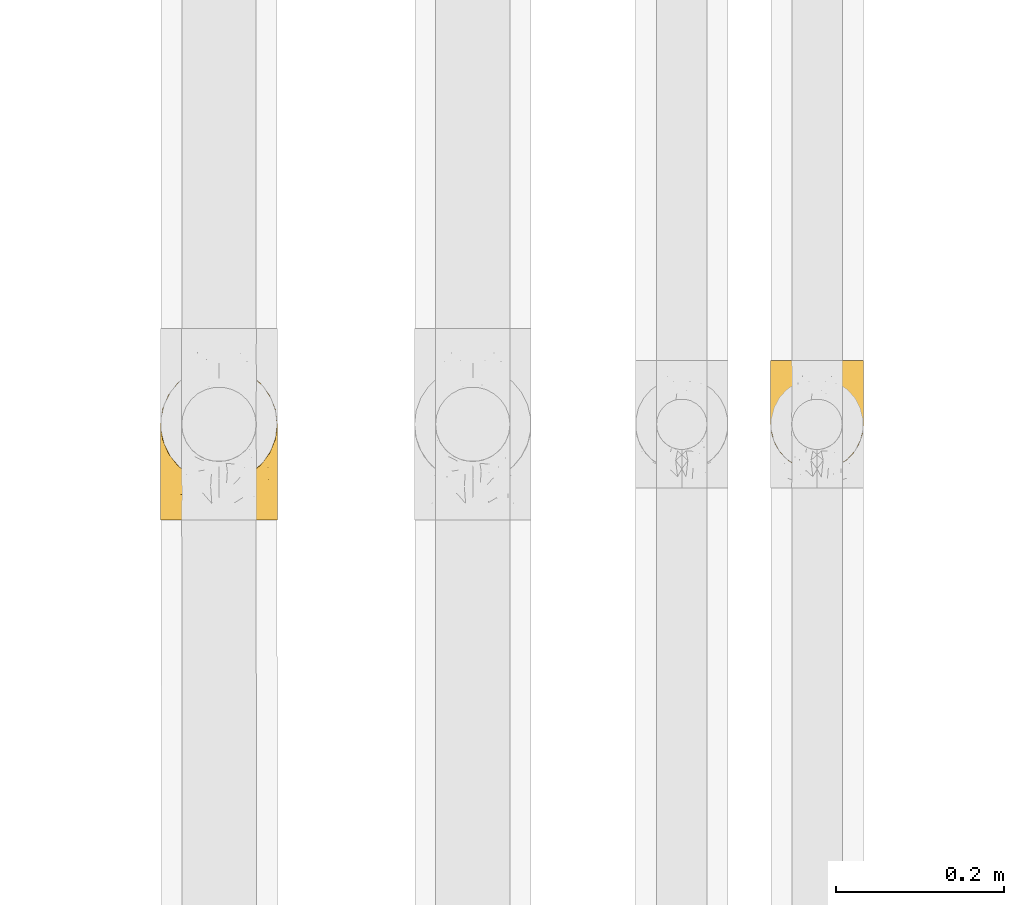
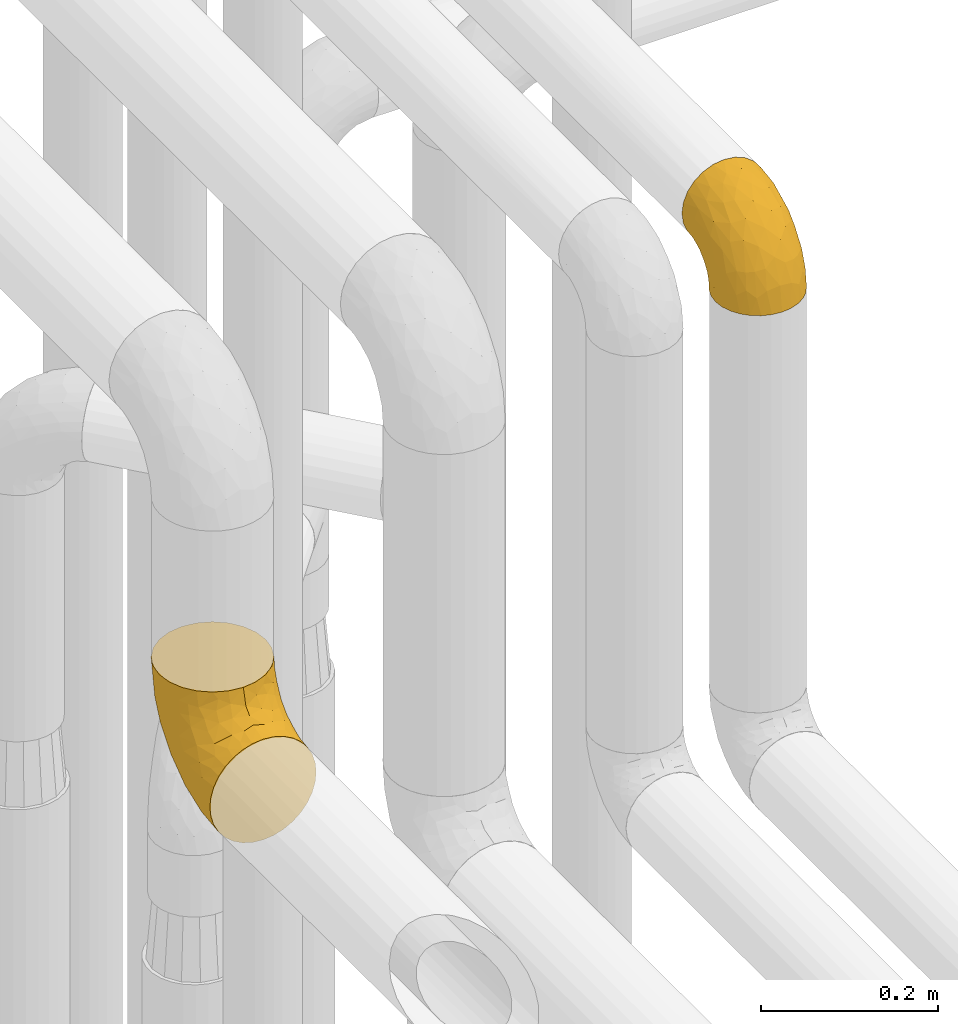
# One storey, part 189 of 827: 2 coverings.
"""IFC2X3 building model written with IfcOpenShell, lengths in millimetres."""

from ifc_helpers import new_model, entity, si_unit, converted_unit, derived_unit, direction, frame, origin, place, context, subcontext, project, spatial, faceted_brep, element, save


model = new_model("IFC2X3")

# Units and contexts
model_context = context("Model", 3, precision=0.01, world=origin(), true_north=direction((6.12303176911189e-17, 1.0)))
body_context = subcontext(model_context, "Body", "Model", "MODEL_VIEW")
ifc_project = project(units=[si_unit("LENGTHUNIT", "METRE", prefix="MILLI"), si_unit("AREAUNIT", "SQUARE_METRE"), si_unit("VOLUMEUNIT", "CUBIC_METRE"), converted_unit("PLANEANGLEUNIT", "DEGREE", entity("IfcRatioMeasure", 0.0174532925199433), si_unit("PLANEANGLEUNIT", "RADIAN"), dimensions=[0, 0, 0, 0, 0, 0, 0]), si_unit("MASSUNIT", "GRAM", prefix="KILO"), derived_unit("MASSDENSITYUNIT", [(si_unit("MASSUNIT", "GRAM", prefix="KILO"), 1), (si_unit("LENGTHUNIT", "METRE"), -3)]), derived_unit("MOMENTOFINERTIAUNIT", [(si_unit("LENGTHUNIT", "METRE"), 4)]), si_unit("TIMEUNIT", "SECOND"), si_unit("FREQUENCYUNIT", "HERTZ"), si_unit("THERMODYNAMICTEMPERATUREUNIT", "DEGREE_CELSIUS"), derived_unit("THERMALTRANSMITTANCEUNIT", [(si_unit("MASSUNIT", "GRAM", prefix="KILO"), 1), (si_unit("THERMODYNAMICTEMPERATUREUNIT", "KELVIN"), -1), (si_unit("TIMEUNIT", "SECOND"), -3)]), derived_unit("VOLUMETRICFLOWRATEUNIT", [(si_unit("LENGTHUNIT", "METRE"), 3), (si_unit("TIMEUNIT", "SECOND"), -1)]), derived_unit("MASSFLOWRATEUNIT", [(si_unit("MASSUNIT", "GRAM", prefix="KILO"), 1), (si_unit("TIMEUNIT", "SECOND"), -1)]), derived_unit("ROTATIONALFREQUENCYUNIT", [(si_unit("TIMEUNIT", "SECOND"), -1)]), si_unit("ELECTRICCURRENTUNIT", "AMPERE"), si_unit("ELECTRICVOLTAGEUNIT", "VOLT"), si_unit("POWERUNIT", "WATT"), si_unit("FORCEUNIT", "NEWTON", prefix="KILO"), si_unit("ILLUMINANCEUNIT", "LUX"), si_unit("LUMINOUSFLUXUNIT", "LUMEN"), si_unit("LUMINOUSINTENSITYUNIT", "CANDELA"), derived_unit("USERDEFINED", [(si_unit("MASSUNIT", "GRAM", prefix="KILO"), -1), (si_unit("LENGTHUNIT", "METRE"), -2), (si_unit("TIMEUNIT", "SECOND"), 3), (si_unit("LUMINOUSFLUXUNIT", "LUMEN"), 1)]), derived_unit("LINEARVELOCITYUNIT", [(si_unit("LENGTHUNIT", "METRE"), 1), (si_unit("TIMEUNIT", "SECOND"), -1)]), si_unit("PRESSUREUNIT", "PASCAL"), derived_unit("USERDEFINED", [(si_unit("LENGTHUNIT", "METRE"), -2), (si_unit("MASSUNIT", "GRAM", prefix="KILO"), 1), (si_unit("TIMEUNIT", "SECOND"), -2)]), derived_unit("LINEARFORCEUNIT", [(si_unit("MASSUNIT", "GRAM", prefix="KILO"), 1), (si_unit("LENGTHUNIT", "METRE"), 1), (si_unit("TIMEUNIT", "SECOND"), -2), (si_unit("LENGTHUNIT", "METRE"), -1)]), derived_unit("PLANARFORCEUNIT", [(si_unit("MASSUNIT", "GRAM", prefix="KILO"), 1), (si_unit("LENGTHUNIT", "METRE"), 1), (si_unit("TIMEUNIT", "SECOND"), -2), (si_unit("LENGTHUNIT", "METRE"), -2)])], contexts=[model_context])

# Site, building, storey
site_placement = place(None, origin())
site = spatial("IfcSite", under=ifc_project, at=site_placement, CompositionType="ELEMENT")
building_placement = place(site_placement, origin())
building = spatial("IfcBuilding", under=site, at=building_placement, CompositionType="ELEMENT")
storey_placement = place(building_placement, frame((0.0, 0.0, 28200.0)))
storey = spatial("IfcBuildingStorey", under=building, at=storey_placement, Name="08", CompositionType="ELEMENT", Elevation=28200.0)

# Coverings
covering_1_placement = place(storey_placement, frame((36572.9, 8750.64, 3472.4)))
element("IfcCovering", 1, at=covering_1_placement, inside=storey, Name=":ADSK_", ObjectType=":ADSK_", PredefinedType="INSULATION", context=body_context, shape_type="Brep", body=[
    faceted_brep([(111.9, 56.75, 1.6), (110.51, 44.47, 1.6), (106.43, 32.81, 1.6), (99.86, 22.35, 1.6), (91.12, 13.62, 1.6), (80.66, 7.05, 1.6), (69.0, 2.97, 1.6), (56.75, 1.6, 1.6), (44.47, 2.98, 1.6), (32.81, 7.06, 1.6), (22.35, 13.63, 1.6), (13.62, 22.37, 1.6), (7.05, 32.83, 1.6), (2.97, 44.49, 1.6), (1.6, 56.75, 1.6), (2.55, 65.19, 1.6), (2.98, 69.02, 1.6), (5.02, 74.85, 1.6), (7.06, 80.68, 1.6), (13.63, 91.14, 1.6), (22.37, 99.87, 1.6), (32.83, 106.44, 1.6), (44.49, 110.52, 1.6), (56.75, 111.9, 1.6), (69.02, 110.51, 1.6), (80.68, 106.43, 1.6), (91.14, 99.86, 1.6), (99.87, 91.12, 1.6), (106.44, 80.66, 1.6), (108.48, 74.83, 1.6), (110.52, 69.0, 1.6), (110.95, 65.19, 1.6), (42.47, 132.75, 24.32), (29.17, 132.75, 29.83), (17.75, 132.75, 38.6), (13.37, 132.75, 44.31), (8.98, 132.75, 50.02), (3.47, 132.75, 63.32), (2.71, 132.75, 69.12), (2.15, 132.75, 73.36), (1.6, 132.75, 77.6), (3.47, 132.75, 91.87), (8.98, 132.75, 105.17), (17.75, 132.75, 116.59), (29.17, 132.75, 125.36), (42.47, 132.75, 130.87), (56.75, 132.75, 132.75), (71.02, 132.75, 130.87), (84.32, 132.75, 125.36), (95.74, 132.75, 116.59), (104.51, 132.75, 105.17), (110.02, 132.75, 91.87), (111.9, 132.75, 77.6), (110.78, 132.75, 69.12), (110.02, 132.75, 63.32), (104.51, 132.75, 50.02), (100.12, 132.75, 44.31), (95.74, 132.75, 38.6), (84.32, 132.75, 29.83), (71.02, 132.75, 24.32), (56.75, 132.75, 22.45), (106.06, 106.09, 98.7), (110.5, 106.29, 85.87), (56.75, 98.8, 128.28), (66.53, 110.62, 129.98), (76.28, 79.56, 117.55), (86.35, 82.88, 113.52), (75.96, 101.82, 125.49), (88.56, 109.51, 120.4), (110.32, 60.24, 53.38), (111.9, 62.53, 30.68), (111.9, 66.65, 36.84), (111.9, 70.77, 43.01), (111.9, 74.89, 49.17), (111.9, 79.01, 55.34), (107.8, 75.42, 79.67), (101.47, 78.6, 95.35), (73.78, 54.94, 103.8), (56.75, 67.17, 115.17), (56.75, 40.01, 94.33), (98.04, 101.35, 109.68), (101.71, 27.42, 25.2), (56.75, 6.06, 35.54), (73.2, 7.89, 32.54), (104.0, 54.81, 71.11), (110.96, 49.8, 24.73), (111.08, 83.59, 71.5), (111.9, 85.17, 59.45), (111.9, 91.33, 63.57), (111.9, 97.5, 67.69), (111.9, 103.66, 71.81), (93.24, 19.66, 32.94), (98.07, 32.92, 53.51), (66.48, 86.86, 123.53), (82.04, 19.74, 55.05), (71.11, 29.98, 79.98), (68.82, 15.6, 57.53), (84.42, 11.19, 24.57), (84.13, 42.02, 85.93), (111.9, 58.54, 10.61), (111.9, 60.33, 19.62), (90.72, 25.28, 53.74), (89.42, 62.01, 99.07), (105.96, 42.85, 47.38), (107.26, 37.14, 23.67), (56.75, 19.17, 67.17), (96.16, 51.44, 82.32), (111.9, 114.72, 74.01), (111.9, 119.22, 74.91), (111.9, 123.73, 75.8), (106.76, 115.76, 51.54), (110.57, 110.4, 61.55), (110.3, 102.67, 56.74), (110.29, 119.74, 63.04), (94.17, 125.52, 36.34), (101.01, 123.09, 43.61), (98.9, 115.24, 38.04), (105.68, 124.18, 51.43), (106.0, 108.76, 46.81), (103.59, 105.53, 39.79), (67.59, 112.2, 9.27), (82.4, 109.92, 16.36), (78.41, 108.4, 8.4), (103.94, 89.3, 20.7), (109.96, 78.37, 30.35), (108.51, 78.09, 17.66), (95.93, 110.58, 31.46), (91.02, 108.54, 23.73), (82.23, 114.9, 21.98), (69.32, 124.4, 22.28), (87.66, 124.83, 30.88), (99.66, 92.2, 9.8), (92.5, 100.98, 13.74), (110.75, 69.61, 16.21), (108.97, 87.39, 38.18), (94.99, 102.3, 21.3), (111.03, 70.27, 23.76), (70.18, 116.83, 17.51), (56.75, 114.69, 12.02), (56.75, 122.32, 19.65), (104.65, 94.21, 31.33), (84.42, 120.17, 26.94), (106.33, 96.46, 38.65), (108.73, 97.77, 47.33), (110.14, 89.34, 46.16), (99.67, 101.91, 29.19), (29.08, 120.17, 26.94), (25.83, 124.84, 30.88), (3.2, 102.67, 56.74), (1.6, 97.5, 67.69), (2.92, 110.4, 61.55), (44.17, 124.4, 22.28), (1.6, 58.54, 10.61), (1.6, 60.33, 19.62), (3.35, 89.33, 46.16), (1.6, 79.01, 55.34), (1.6, 85.17, 59.45), (43.33, 116.83, 17.51), (45.92, 112.21, 9.26), (21.01, 101.0, 13.74), (31.11, 109.94, 16.36), (35.1, 108.4, 8.4), (1.6, 114.72, 74.01), (1.6, 123.73, 75.8), (1.6, 128.24, 76.7), (17.57, 110.6, 31.46), (22.49, 108.57, 23.73), (13.83, 101.94, 29.19), (19.33, 125.53, 36.34), (11.9, 119.28, 43.38), (4.99, 78.12, 17.66), (1.6, 103.66, 71.81), (3.2, 119.74, 63.04), (6.74, 115.76, 51.54), (7.5, 108.77, 46.81), (7.81, 124.18, 51.43), (4.53, 87.39, 38.15), (1.6, 74.89, 49.17), (1.6, 62.53, 30.68), (2.75, 69.63, 16.19), (13.84, 92.22, 9.8), (18.52, 102.32, 21.3), (9.57, 89.33, 20.71), (3.54, 78.39, 30.35), (9.91, 105.54, 39.78), (2.46, 70.28, 23.75), (1.6, 66.65, 36.84), (14.6, 115.25, 38.04), (8.86, 94.22, 31.3), (7.16, 96.46, 38.64), (4.77, 97.78, 47.32), (31.28, 114.91, 21.97), (1.6, 70.77, 43.01), (1.6, 91.33, 63.57), (2.41, 83.59, 71.49), (7.44, 106.09, 98.7), (7.52, 42.86, 47.37), (3.17, 60.25, 53.37), (2.53, 49.81, 24.72), (47.01, 88.41, 124.11), (2.99, 106.29, 85.87), (37.53, 101.81, 125.49), (47.09, 110.86, 130.04), (24.94, 109.5, 120.4), (15.45, 101.34, 109.68), (27.14, 82.87, 113.51), (29.35, 42.02, 85.93), (42.38, 29.98, 79.98), (39.72, 54.94, 103.8), (5.69, 75.43, 79.67), (17.32, 51.45, 82.31), (12.02, 78.59, 95.34), (9.48, 54.82, 71.09), (11.77, 27.44, 25.2), (15.41, 32.93, 53.51), (31.43, 19.76, 55.07), (20.24, 19.67, 32.95), (22.76, 25.31, 53.76), (24.06, 62.02, 99.06), (40.27, 7.9, 32.56), (29.05, 11.2, 24.57), (43.27, 15.96, 57.51), (38.2, 77.26, 116.87), (6.22, 37.15, 23.67)], [[[0, 1, 2, 3, 4, 5, 6, 7, 8, 9, 10, 11, 12, 13, 14, 15, 16, 17, 18, 19, 20, 21, 22, 23, 24, 25, 26, 27, 28, 29, 30, 31]], [[32, 33, 34, 35, 36, 37, 38, 39, 40, 41, 42, 43, 44, 45, 46, 47, 48, 49, 50, 51, 52, 53, 54, 55, 56, 57, 58, 59, 60]], [[51, 61, 62]], [[46, 63, 64]], [[65, 66, 67]], [[67, 66, 68]], [[69, 70, 71, 72, 73, 74]], [[75, 61, 76]], [[77, 78, 79]], [[61, 50, 80]], [[49, 80, 50]], [[68, 49, 48]], [[81, 3, 2]], [[82, 6, 83]], [[48, 47, 67]], [[52, 51, 62]], [[84, 75, 76]], [[85, 1, 0]], [[86, 74, 87, 88, 89, 90]], [[91, 81, 92]], [[93, 65, 67]], [[94, 95, 96]], [[49, 68, 80]], [[79, 95, 77]], [[5, 83, 6]], [[82, 83, 96]], [[97, 5, 4]], [[6, 82, 7]], [[84, 69, 75]], [[86, 69, 74]], [[98, 77, 95]], [[97, 83, 5]], [[85, 0, 99, 100, 70]], [[101, 91, 92]], [[77, 98, 102]], [[91, 4, 3]], [[103, 104, 85]], [[103, 81, 104]], [[102, 76, 80]], [[64, 93, 67]], [[97, 94, 83]], [[47, 64, 67]], [[50, 61, 51]], [[81, 91, 3]], [[96, 95, 105]], [[79, 105, 95]], [[101, 98, 94]], [[4, 91, 97]], [[94, 97, 91]], [[104, 81, 2]], [[92, 81, 103]], [[84, 92, 103]], [[106, 98, 101]], [[76, 61, 80]], [[75, 86, 62]], [[102, 80, 66]], [[84, 76, 106]], [[75, 62, 61]], [[62, 90, 107, 108, 109, 52]], [[70, 69, 85]], [[103, 85, 69]], [[94, 98, 95]], [[102, 98, 106]], [[2, 1, 104]], [[85, 104, 1]], [[67, 68, 48]], [[80, 68, 66]], [[62, 86, 90]], [[69, 86, 75]], [[76, 102, 106]], [[77, 102, 66]], [[92, 84, 106]], [[69, 84, 103]], [[46, 64, 47]], [[93, 64, 63]], [[63, 78, 93]], [[77, 93, 78]], [[93, 77, 65]], [[77, 66, 65]], [[82, 96, 105]], [[94, 96, 83]], [[101, 92, 106]], [[94, 91, 101]], [[110, 111, 112]], [[107, 90, 113]], [[114, 115, 116]], [[54, 107, 113]], [[115, 56, 117]], [[118, 119, 116]], [[120, 121, 122]], [[123, 124, 125]], [[99, 0, 31, 30, 100]], [[126, 127, 128]], [[129, 60, 59]], [[58, 114, 130]], [[131, 132, 123]], [[29, 28, 133]], [[130, 59, 58]], [[114, 58, 57]], [[134, 72, 124]], [[121, 127, 135]], [[26, 25, 132]], [[27, 131, 125]], [[27, 125, 28]], [[136, 133, 125]], [[120, 137, 121]], [[137, 138, 139]], [[126, 116, 119]], [[133, 70, 100]], [[138, 120, 23]], [[100, 29, 133]], [[123, 135, 140]], [[129, 141, 128]], [[53, 52, 109, 108, 107, 54]], [[25, 122, 132]], [[24, 122, 25]], [[55, 113, 117]], [[26, 131, 27]], [[142, 119, 143]], [[111, 89, 112]], [[112, 87, 143]], [[144, 134, 142]], [[118, 110, 112]], [[129, 137, 139]], [[128, 141, 126]], [[111, 113, 90]], [[54, 113, 55]], [[74, 73, 144]], [[145, 142, 140]], [[122, 24, 120]], [[132, 122, 121]], [[23, 120, 24]], [[137, 120, 138]], [[60, 129, 139]], [[141, 129, 59]], [[100, 30, 29]], [[28, 125, 133]], [[134, 124, 123]], [[124, 71, 136]], [[89, 88, 87, 112]], [[111, 110, 117]], [[143, 87, 144]], [[118, 116, 115]], [[112, 143, 118]], [[119, 118, 143]], [[143, 144, 142]], [[126, 119, 145]], [[127, 126, 145]], [[130, 126, 141]], [[140, 142, 134]], [[145, 119, 142]], [[135, 127, 145]], [[127, 121, 128]], [[121, 137, 128]], [[129, 128, 137]], [[73, 72, 134]], [[111, 90, 89]], [[74, 144, 87]], [[134, 123, 140]], [[135, 123, 132]], [[140, 135, 145]], [[121, 135, 132]], [[132, 131, 26]], [[125, 131, 123]], [[115, 114, 57]], [[116, 126, 130]], [[111, 117, 113]], [[115, 110, 118]], [[115, 117, 110]], [[115, 57, 56]], [[56, 55, 117]], [[116, 130, 114]], [[59, 130, 141]], [[144, 73, 134]], [[124, 136, 125]], [[70, 133, 136]], [[71, 124, 72]], [[71, 70, 136]], [[32, 146, 147]], [[148, 149, 150]], [[60, 139, 151]], [[15, 14, 152, 153, 16]], [[154, 155, 156]], [[138, 157, 139]], [[138, 158, 157]], [[159, 160, 161]], [[39, 38, 37, 162, 163, 164, 40]], [[165, 166, 167]], [[168, 169, 34]], [[33, 168, 34]], [[170, 19, 18]], [[171, 162, 172]], [[173, 174, 148]], [[169, 173, 175]], [[161, 158, 22]], [[154, 176, 177]], [[23, 22, 158]], [[178, 179, 153]], [[172, 37, 36]], [[20, 19, 180]], [[21, 20, 159]], [[167, 166, 181]], [[170, 182, 180]], [[182, 170, 183]], [[167, 184, 165]], [[185, 186, 183]], [[170, 179, 185]], [[17, 153, 179]], [[157, 151, 139]], [[187, 168, 147]], [[182, 188, 181]], [[22, 21, 161]], [[189, 154, 190]], [[180, 159, 20]], [[172, 150, 171]], [[190, 184, 189]], [[188, 167, 181]], [[190, 174, 184]], [[166, 191, 160]], [[151, 146, 32]], [[37, 172, 162]], [[175, 36, 35]], [[188, 176, 189]], [[176, 182, 183]], [[159, 161, 21]], [[158, 160, 157]], [[158, 161, 160]], [[23, 158, 138]], [[151, 157, 191]], [[60, 151, 32]], [[170, 18, 179]], [[17, 16, 153]], [[183, 170, 185]], [[179, 178, 185]], [[175, 150, 172]], [[150, 173, 148]], [[173, 169, 174]], [[154, 156, 190]], [[184, 174, 187]], [[190, 148, 174]], [[165, 184, 187]], [[189, 176, 154]], [[147, 165, 187]], [[191, 166, 165]], [[184, 167, 189]], [[188, 189, 167]], [[191, 165, 146]], [[181, 160, 159]], [[151, 191, 146]], [[157, 160, 191]], [[176, 192, 177]], [[148, 190, 156]], [[149, 148, 156, 193]], [[149, 171, 150]], [[182, 176, 188]], [[160, 181, 166]], [[181, 159, 182]], [[170, 180, 19]], [[159, 180, 182]], [[147, 168, 33]], [[169, 168, 187]], [[174, 169, 187]], [[35, 169, 175]], [[150, 175, 173]], [[34, 169, 35]], [[172, 36, 175]], [[32, 147, 33]], [[147, 146, 165]], [[192, 176, 183]], [[155, 154, 177]], [[192, 183, 186]], [[185, 178, 186]], [[179, 18, 17]], [[194, 171, 149, 193, 156, 155]], [[195, 42, 41]], [[196, 197, 198]], [[78, 63, 199]], [[197, 155, 177, 192, 186, 178]], [[200, 40, 164, 163, 162, 171]], [[201, 199, 202]], [[203, 204, 205]], [[46, 45, 202]], [[206, 207, 208]], [[194, 197, 209]], [[203, 201, 44]], [[44, 201, 45]], [[43, 203, 44]], [[210, 211, 212]], [[204, 43, 42]], [[212, 197, 196]], [[78, 208, 79]], [[198, 178, 153, 152, 14]], [[204, 195, 211]], [[14, 13, 198]], [[196, 213, 214]], [[206, 215, 207]], [[213, 11, 216]], [[204, 42, 195]], [[11, 213, 12]], [[210, 217, 206]], [[216, 11, 10]], [[210, 206, 218]], [[219, 220, 9]], [[220, 10, 9]], [[207, 105, 79]], [[221, 207, 215]], [[222, 199, 201]], [[8, 7, 82]], [[8, 82, 219]], [[209, 195, 200]], [[215, 216, 220]], [[9, 8, 219]], [[207, 79, 208]], [[221, 82, 105]], [[12, 213, 223]], [[222, 201, 205]], [[204, 211, 218]], [[221, 215, 219]], [[215, 220, 219]], [[216, 10, 220]], [[214, 213, 216]], [[223, 213, 196]], [[217, 214, 216]], [[212, 214, 210]], [[200, 195, 41]], [[211, 195, 209]], [[212, 211, 209]], [[211, 210, 218]], [[40, 200, 41]], [[200, 171, 194]], [[198, 13, 223]], [[197, 178, 198]], [[218, 208, 205]], [[210, 214, 217]], [[198, 223, 196]], [[13, 12, 223]], [[204, 203, 43]], [[201, 203, 205]], [[197, 194, 155]], [[200, 194, 209]], [[208, 218, 206]], [[218, 205, 204]], [[197, 212, 209]], [[214, 212, 196]], [[205, 208, 222]], [[78, 222, 208]], [[78, 199, 222]], [[202, 199, 63]], [[46, 202, 63]], [[201, 202, 45]], [[82, 221, 219]], [[105, 207, 221]], [[216, 215, 217]], [[206, 217, 215]]]),
])
covering_2_placement = place(storey_placement, frame((35847.02, 8691.74, 3028.95)))
element("IfcCovering", 2, at=covering_2_placement, inside=storey, Name=":ADSK_", ObjectType=":ADSK_", PredefinedType="INSULATION", context=body_context, shape_type="Brep", body=[
    faceted_brep([(3.02, 1.6, 84.59), (1.69, 1.6, 71.05), (3.02, 1.6, 57.49), (6.98, 1.6, 44.46), (13.4, 1.6, 32.45), (22.04, 1.61, 21.93), (32.56, 1.62, 13.29), (44.57, 1.63, 6.88), (57.6, 1.64, 2.93), (71.14, 1.65, 1.6), (84.69, 1.66, 2.93), (97.72, 1.67, 6.88), (109.73, 1.68, 13.3), (120.25, 1.69, 21.94), (128.89, 1.7, 32.47), (135.3, 1.7, 44.48), (139.25, 1.71, 57.5), (140.59, 1.71, 71.05), (139.25, 1.71, 84.6), (135.3, 1.7, 97.63), (128.88, 1.7, 109.64), (120.24, 1.69, 120.16), (109.71, 1.68, 128.8), (97.71, 1.67, 135.21), (84.68, 1.66, 139.16), (71.14, 1.65, 140.5), (57.58, 1.64, 139.16), (44.55, 1.63, 135.21), (32.55, 1.62, 128.79), (22.02, 1.61, 120.15), (13.39, 1.6, 109.62), (6.97, 1.6, 97.62), (71.1, 46.2, 185.05), (89.07, 48.58, 185.05), (105.82, 55.53, 185.05), (120.19, 66.58, 185.05), (131.22, 80.98, 185.05), (138.14, 97.73, 185.05), (140.5, 115.71, 185.05), (138.11, 133.68, 185.05), (131.16, 150.43, 185.05), (120.11, 164.8, 185.05), (105.72, 175.83, 185.05), (88.97, 182.75, 185.05), (70.99, 185.1, 185.05), (53.02, 182.72, 185.05), (36.27, 175.77, 185.05), (21.9, 164.72, 185.05), (10.87, 150.33, 185.05), (3.95, 133.57, 185.05), (1.6, 115.6, 185.05), (3.98, 97.62, 185.05), (10.93, 80.88, 185.05), (21.98, 66.5, 185.05), (36.37, 55.48, 185.05), (53.12, 48.55, 185.05), (30.71, 168.98, 152.15), (46.55, 175.16, 141.12), (33.18, 158.76, 114.51), (58.51, 181.23, 153.61), (70.99, 178.85, 137.56), (21.21, 60.47, 33.77), (11.86, 37.65, 39.19), (13.85, 67.77, 46.71), (7.02, 122.9, 113.31), (10.5, 141.28, 135.94), (17.92, 138.24, 104.19), (4.5, 130.26, 147.85), (2.77, 112.44, 123.66), (3.23, 49.74, 65.65), (7.67, 68.05, 59.18), (5.82, 30.87, 50.51), (45.96, 163.58, 109.33), (58.66, 171.55, 118.86), (18.68, 154.97, 140.66), (71.1, 49.13, 7.85), (52.61, 41.68, 8.59), (57.25, 76.32, 19.01), (42.25, 71.52, 22.23), (3.68, 94.09, 92.55), (9.98, 104.14, 79.62), (1.63, 68.6, 92.82), (1.61, 93.82, 118.04), (1.61, 101.92, 133.93), (1.6, 110.02, 149.82), (19.14, 29.3, 27.39), (49.37, 144.81, 75.97), (71.01, 160.52, 93.32), (71.03, 131.37, 55.33), (40.43, 41.73, 13.36), (29.26, 37.38, 19.44), (53.12, 111.51, 41.09), (1.67, 17.55, 73.57), (1.66, 36.82, 76.62), (35.64, 118.95, 56.89), (28.88, 138.31, 85.33), (21.42, 90.61, 49.01), (71.06, 93.38, 26.17), (1.62, 81.21, 105.43), (30.98, 81.17, 34.01), (1.6, 113.07, 169.09), (20.14, 115.62, 71.03), (40.98, 98.75, 37.55), (1.65, 52.71, 84.72), (44.76, 25.35, 141.32), (51.99, 37.49, 154.3), (37.24, 41.94, 150.07), (4.03, 95.84, 167.57), (3.3, 94.09, 150.42), (22.37, 62.75, 164.49), (2.6, 17.88, 83.63), (5.26, 25.24, 96.18), (33.75, 16.56, 131.63), (20.68, 22.29, 122.1), (8.4, 83.67, 166.75), (41.7, 51.81, 175.54), (37.96, 49.59, 162.59), (54.01, 45.41, 168.81), (57.95, 22.0, 144.01), (14.39, 72.89, 165.65), (25.45, 32.44, 131.63), (3.1, 50.57, 98.0), (3.64, 63.77, 110.02), (48.06, 12.87, 137.87), (25.07, 54.59, 152.86), (12.08, 49.26, 124.07), (12.87, 18.25, 110.7), (71.13, 17.14, 144.65), (71.12, 23.93, 146.46), (8.58, 37.06, 109.13), (2.78, 89.71, 134.98), (4.15, 75.21, 124.3), (7.74, 79.99, 150.87), (71.11, 32.08, 154.62), (13.64, 69.2, 152.63), (24.74, 45.44, 140.78), (12.62, 63.69, 140.33), (71.11, 40.23, 162.77), (71.1, 42.05, 169.55), (84.29, 22.02, 144.01), (138.1, 95.95, 167.57), (133.75, 83.77, 166.75), (138.72, 93.43, 149.67), (90.23, 37.52, 154.3), (127.77, 72.98, 165.65), (134.41, 80.09, 150.87), (88.19, 45.44, 168.82), (104.23, 49.65, 162.6), (108.49, 16.61, 131.64), (121.54, 22.37, 122.11), (100.49, 51.86, 175.55), (136.97, 25.35, 96.2), (140.56, 36.94, 76.62), (140.55, 52.83, 84.72), (140.5, 113.18, 169.09), (140.5, 110.13, 149.82), (119.8, 62.83, 164.49), (130.1, 49.34, 124.09), (116.76, 32.51, 131.64), (129.54, 63.78, 140.35), (117.44, 45.5, 140.79), (128.13, 68.82, 152.98), (117.11, 54.66, 152.86), (94.18, 12.89, 137.88), (140.57, 17.67, 73.57), (129.37, 18.35, 110.71), (139.1, 50.68, 98.01), (133.64, 37.16, 109.15), (138.0, 75.31, 124.3), (97.46, 25.38, 141.32), (139.65, 18.0, 83.62), (104.29, 38.18, 146.63), (140.51, 93.94, 118.04), (139.02, 87.74, 134.71), (138.53, 63.88, 110.02), (140.53, 68.72, 92.82), (140.52, 81.33, 105.43), (140.51, 102.03, 133.93), (108.84, 158.82, 114.51), (111.3, 169.05, 152.15), (123.34, 155.06, 140.66), (136.41, 30.97, 50.53), (128.32, 67.85, 46.72), (130.36, 37.75, 39.21), (120.98, 60.56, 33.78), (139.33, 112.55, 123.66), (124.13, 138.32, 104.19), (106.44, 119.01, 56.89), (120.73, 90.68, 49.02), (111.18, 81.25, 34.02), (138.45, 94.2, 92.55), (137.56, 130.37, 147.85), (101.16, 98.79, 37.56), (131.55, 141.38, 135.94), (83.45, 181.26, 153.66), (95.45, 175.2, 141.12), (83.36, 172.62, 121.64), (134.5, 68.16, 59.2), (138.97, 49.85, 65.65), (135.06, 123.01, 113.31), (95.2, 162.88, 107.01), (88.97, 111.54, 41.09), (92.67, 144.84, 75.97), (132.13, 104.24, 79.62), (123.1, 29.39, 27.41), (102.11, 30.53, 11.27), (121.95, 115.71, 71.03), (112.97, 37.45, 19.45), (99.92, 71.58, 22.24), (89.61, 41.72, 8.6), (84.91, 76.36, 19.02), (83.79, 159.71, 94.27), (113.17, 138.38, 85.33)], [[[0, 1, 2, 3, 4, 5, 6, 7, 8, 9, 10, 11, 12, 13, 14, 15, 16, 17, 18, 19, 20, 21, 22, 23, 24, 25, 26, 27, 28, 29, 30, 31]], [[32, 33, 34, 35, 36, 37, 38, 39, 40, 41, 42, 43, 44, 45, 46, 47, 48, 49, 50, 51, 52, 53, 54, 55]], [[56, 57, 58]], [[59, 44, 60]], [[46, 45, 57]], [[61, 62, 63]], [[64, 65, 66]], [[67, 64, 68]], [[69, 70, 71]], [[57, 72, 58]], [[62, 4, 3]], [[72, 57, 73]], [[74, 47, 56]], [[47, 46, 56]], [[75, 8, 76]], [[77, 76, 78]], [[48, 74, 65]], [[50, 49, 67]], [[79, 64, 80]], [[69, 81, 79]], [[68, 82, 83, 84]], [[64, 66, 80]], [[85, 62, 61]], [[86, 87, 88]], [[7, 6, 89]], [[47, 74, 48]], [[8, 7, 76]], [[85, 5, 4]], [[89, 6, 90]], [[8, 75, 9]], [[59, 73, 57]], [[45, 59, 57]], [[5, 85, 90]], [[63, 62, 70]], [[91, 86, 88]], [[68, 79, 82]], [[69, 1, 92, 93]], [[94, 86, 91]], [[86, 94, 95]], [[71, 62, 3]], [[76, 89, 78]], [[61, 63, 96]], [[88, 97, 91]], [[79, 81, 98, 82]], [[90, 6, 5]], [[99, 90, 61]], [[71, 3, 2]], [[76, 77, 75]], [[58, 95, 66]], [[79, 70, 69]], [[67, 65, 64]], [[77, 91, 97]], [[61, 96, 99]], [[2, 1, 69]], [[70, 62, 71]], [[67, 84, 100, 50]], [[79, 68, 64]], [[84, 67, 68]], [[65, 49, 48]], [[65, 67, 49]], [[66, 65, 74]], [[58, 66, 74]], [[66, 101, 80]], [[99, 102, 78]], [[95, 101, 66]], [[62, 85, 4]], [[90, 85, 61]], [[80, 101, 96]], [[70, 79, 80]], [[86, 95, 58]], [[94, 101, 95]], [[2, 69, 71]], [[69, 93, 103, 81]], [[57, 56, 46]], [[74, 56, 58]], [[77, 78, 102]], [[75, 77, 97]], [[80, 63, 70]], [[63, 80, 96]], [[101, 94, 96]], [[94, 102, 99]], [[94, 99, 96]], [[90, 99, 78]], [[94, 91, 102]], [[77, 102, 91]], [[7, 89, 76]], [[90, 78, 89]], [[44, 59, 45]], [[73, 59, 60]], [[60, 87, 73]], [[86, 73, 87]], [[73, 86, 72]], [[86, 58, 72]], [[104, 105, 106]], [[100, 84, 107]], [[84, 83, 108]], [[51, 100, 107]], [[54, 53, 109]], [[52, 51, 107]], [[110, 111, 93]], [[28, 27, 112]], [[113, 29, 28]], [[53, 52, 114]], [[54, 115, 55]], [[109, 116, 115]], [[115, 117, 55]], [[118, 105, 104]], [[119, 53, 114]], [[104, 106, 120]], [[121, 122, 81]], [[120, 113, 112]], [[112, 113, 28]], [[123, 112, 27]], [[31, 30, 111]], [[124, 106, 116]], [[113, 120, 125]], [[110, 93, 92]], [[1, 0, 92]], [[121, 81, 103]], [[124, 116, 109]], [[30, 126, 111]], [[51, 50, 100]], [[26, 25, 127]], [[127, 128, 118]], [[110, 92, 0]], [[113, 125, 129]], [[126, 113, 129]], [[29, 126, 30]], [[129, 125, 122]], [[123, 27, 26]], [[130, 131, 132]], [[118, 133, 105]], [[103, 93, 111]], [[127, 118, 26]], [[132, 134, 119]], [[118, 104, 123]], [[32, 55, 117]], [[106, 105, 116]], [[113, 126, 29]], [[111, 126, 129]], [[0, 31, 110]], [[111, 110, 31]], [[118, 123, 26]], [[112, 123, 104]], [[104, 120, 112]], [[120, 135, 125]], [[136, 125, 135]], [[82, 98, 131]], [[136, 135, 124]], [[131, 98, 122]], [[131, 125, 136]], [[98, 81, 122]], [[132, 131, 136]], [[121, 111, 129]], [[125, 131, 122]], [[105, 137, 117]], [[138, 32, 117, 137]], [[111, 121, 103]], [[122, 121, 129]], [[132, 114, 108]], [[114, 52, 107]], [[108, 114, 107]], [[108, 83, 130]], [[114, 132, 119]], [[84, 108, 107]], [[83, 82, 130]], [[131, 130, 82]], [[132, 108, 130]], [[134, 132, 136]], [[53, 119, 109]], [[124, 134, 136]], [[109, 119, 134]], [[109, 115, 54]], [[117, 115, 116]], [[105, 117, 116]], [[124, 109, 134]], [[106, 124, 135]], [[133, 118, 128]], [[133, 137, 105]], [[106, 135, 120]], [[139, 133, 128]], [[140, 141, 142]], [[143, 133, 139]], [[24, 139, 127]], [[141, 144, 145]], [[146, 143, 147]], [[148, 22, 149]], [[150, 34, 33]], [[143, 146, 137]], [[151, 152, 153]], [[36, 140, 37]], [[38, 37, 154]], [[154, 140, 155]], [[144, 35, 156]], [[35, 34, 156]], [[149, 157, 158]], [[157, 159, 160]], [[161, 162, 159]], [[24, 127, 25]], [[128, 127, 139]], [[163, 24, 23]], [[18, 17, 164]], [[140, 154, 37]], [[165, 149, 21]], [[20, 165, 21]], [[160, 158, 157]], [[21, 149, 22]], [[148, 23, 22]], [[151, 153, 166]], [[19, 151, 20]], [[151, 167, 165]], [[159, 168, 145]], [[34, 150, 156]], [[158, 169, 148]], [[164, 152, 170]], [[18, 164, 170]], [[170, 151, 19]], [[147, 143, 171]], [[163, 148, 169]], [[24, 163, 139]], [[162, 156, 147]], [[158, 148, 149]], [[139, 169, 143]], [[171, 143, 169]], [[150, 146, 147]], [[151, 165, 20]], [[149, 165, 167]], [[151, 170, 152]], [[19, 18, 170]], [[148, 163, 23]], [[139, 163, 169]], [[157, 149, 167]], [[158, 160, 171]], [[168, 172, 173]], [[174, 175, 176]], [[176, 168, 174]], [[145, 144, 161]], [[166, 174, 167]], [[172, 168, 176]], [[157, 168, 159]], [[168, 157, 174]], [[167, 174, 157]], [[32, 138, 137, 146]], [[166, 153, 175]], [[174, 166, 175]], [[151, 166, 167]], [[36, 141, 140]], [[177, 142, 173]], [[35, 141, 36]], [[140, 142, 155]], [[142, 141, 145]], [[173, 142, 145]], [[142, 177, 155]], [[168, 173, 145]], [[177, 173, 172]], [[35, 144, 141]], [[161, 144, 156]], [[162, 161, 156]], [[145, 161, 159]], [[33, 32, 146]], [[156, 150, 147]], [[33, 146, 150]], [[171, 162, 147]], [[159, 162, 160]], [[143, 137, 133]], [[158, 171, 169]], [[171, 160, 162]], [[178, 179, 180]], [[15, 181, 16]], [[182, 183, 184]], [[185, 155, 177, 172]], [[180, 186, 178]], [[187, 188, 189]], [[190, 172, 176, 175]], [[191, 38, 154, 155]], [[189, 192, 187]], [[39, 191, 193]], [[44, 43, 194]], [[40, 39, 193]], [[195, 196, 194]], [[179, 195, 42]], [[43, 42, 195]], [[40, 180, 41]], [[183, 182, 197]], [[181, 198, 16]], [[42, 41, 179]], [[185, 191, 155]], [[185, 190, 199]], [[200, 195, 178]], [[201, 88, 202]], [[190, 203, 199]], [[17, 16, 198]], [[181, 15, 183]], [[14, 13, 204]], [[12, 11, 205]], [[203, 206, 186]], [[183, 14, 204]], [[189, 207, 208]], [[204, 207, 184]], [[208, 209, 210]], [[88, 201, 97]], [[11, 209, 205]], [[200, 196, 195]], [[208, 207, 205]], [[10, 75, 209]], [[9, 75, 10]], [[211, 88, 87]], [[87, 60, 196]], [[10, 209, 11]], [[210, 75, 97]], [[12, 207, 13]], [[198, 175, 153, 152]], [[198, 190, 175]], [[212, 178, 186]], [[14, 183, 15]], [[180, 193, 186]], [[187, 201, 202]], [[201, 192, 210]], [[183, 197, 181]], [[198, 181, 197]], [[190, 185, 172]], [[191, 185, 199]], [[191, 199, 193]], [[191, 39, 38]], [[199, 203, 186]], [[40, 193, 180]], [[199, 186, 193]], [[186, 206, 212]], [[212, 202, 178]], [[203, 188, 206]], [[207, 204, 13]], [[183, 204, 184]], [[190, 197, 203]], [[182, 203, 197]], [[206, 187, 212]], [[202, 212, 187]], [[190, 198, 197]], [[198, 152, 164, 17]], [[180, 179, 41]], [[195, 179, 178]], [[75, 210, 209]], [[201, 210, 97]], [[188, 182, 184]], [[182, 188, 203]], [[189, 188, 184]], [[187, 206, 188]], [[207, 189, 184]], [[189, 208, 192]], [[210, 192, 208]], [[201, 187, 192]], [[208, 205, 209]], [[12, 205, 207]], [[178, 202, 200]], [[196, 211, 87]], [[196, 200, 211]], [[194, 196, 60]], [[44, 194, 60]], [[195, 194, 43]], [[200, 202, 211]], [[88, 211, 202]]]),
])

save(model, "model.ifc")
